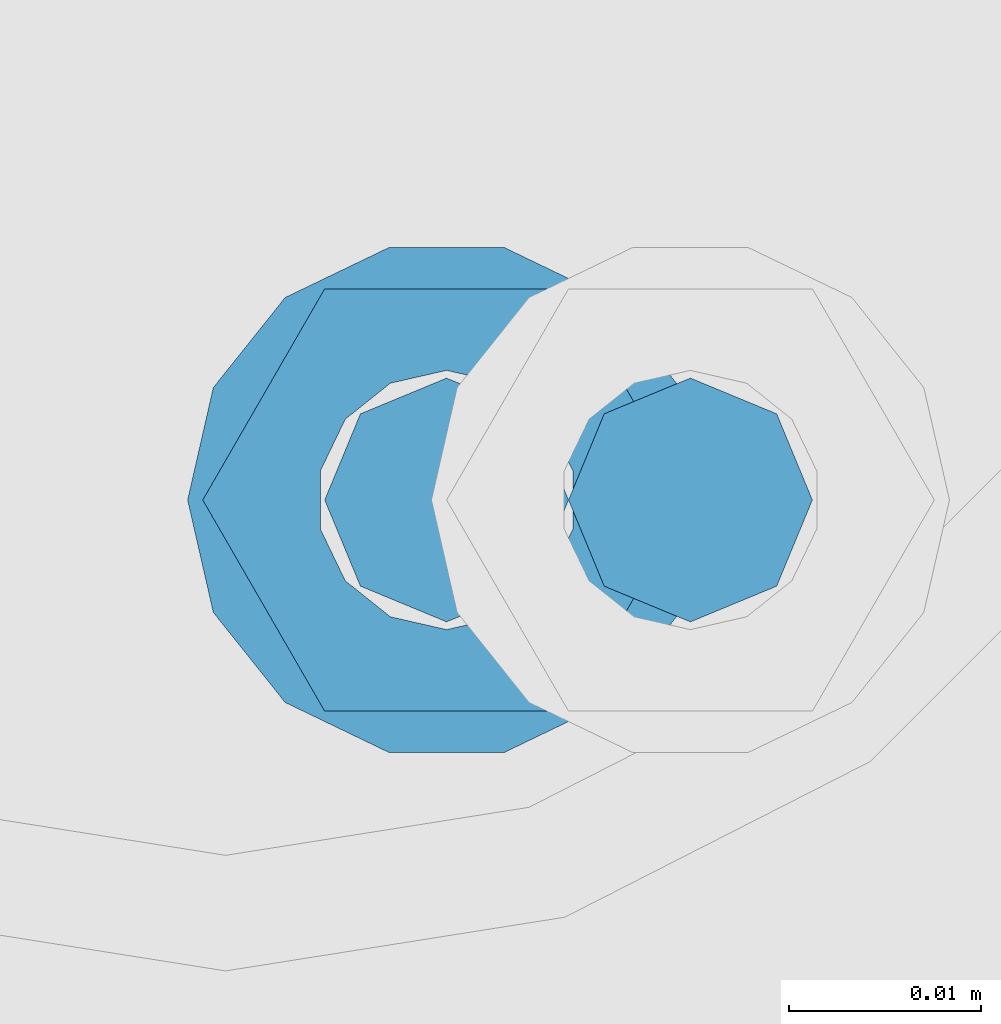
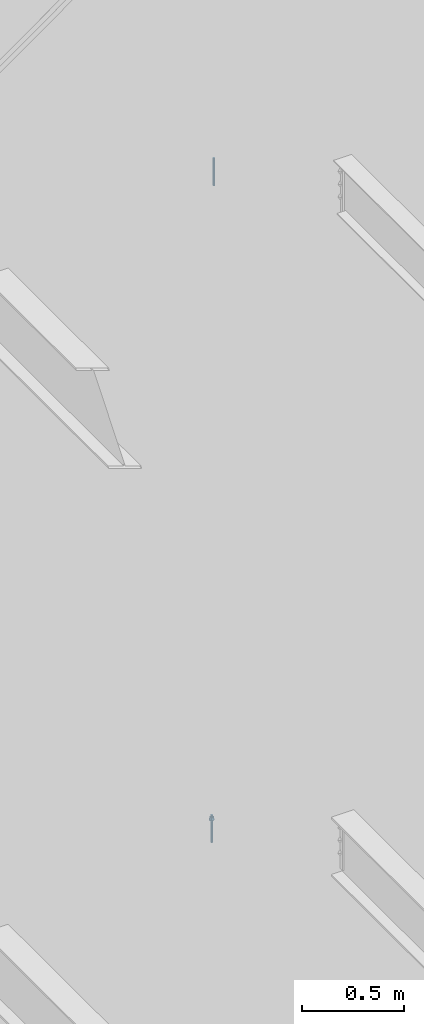
# One storey, part 562 of 1179: 2 columns, 2 elements without a shape of their own.
"""IFC2X3 building model written with IfcOpenShell, lengths in millimetres."""

from ifc_helpers import new_model, si_unit, frame, origin_with_axes, place, context, subcontext, project, spatial, faceted_brep, material, type_object, element, aggregate, save


model = new_model("IFC2X3")

# Units and contexts
model_context = context("Model", 3, precision=1e-05, world=origin_with_axes())
body_context = subcontext(model_context, "Body", "Model", "MODEL_VIEW")
ifc_project = project(units=[si_unit("LENGTHUNIT", "METRE", prefix="MILLI"), si_unit("AREAUNIT", "SQUARE_METRE"), si_unit("VOLUMEUNIT", "CUBIC_METRE"), si_unit("MASSUNIT", "GRAM", prefix="KILO"), si_unit("TIMEUNIT", "SECOND"), si_unit("PLANEANGLEUNIT", "RADIAN"), si_unit("SOLIDANGLEUNIT", "STERADIAN"), si_unit("THERMODYNAMICTEMPERATUREUNIT", "DEGREE_CELSIUS"), si_unit("LUMINOUSINTENSITYUNIT", "LUMEN")], contexts=[model_context])

# Site, building, storey
site_placement = place(None, origin_with_axes())
site = spatial("IfcSite", under=ifc_project, at=site_placement, CompositionType="ELEMENT")
building_placement = place(site_placement, origin_with_axes())
building = spatial("IfcBuilding", under=site, at=building_placement, Name="Undefined", CompositionType="ELEMENT")
storey_placement = place(building_placement, origin_with_axes())
storey = spatial("IfcBuildingStorey", under=building, at=storey_placement, Name="Undefined", CompositionType="ELEMENT", Elevation=0.0)

# Assembly, column
assembly_1_placement = place(storey_placement, origin_with_axes())
assembly_1 = element("IfcElementAssembly", 1, at=assembly_1_placement, inside=storey, Name="BEAM", AssemblyPlace="NOTDEFINED", PredefinedType="RIGID_FRAME")
ifc_material = material(Name="STEEL/A307")
column_type = type_object("IfcColumnType", PredefinedType="NOTDEFINED")
column_1_placement = place(assembly_1_placement, frame((19707.621875, 37985.7, 8013.7), z_axis=(0.0, 1.0, 0.0), x_axis=(0.0, 0.0, 1.0)))
column_1 = element("IfcColumn", 2, at=column_1_placement, type_object=column_type, material=ifc_material, Name="THREADED ROD", context=body_context, shape_type="Brep", body=[
    faceted_brep([(0.0, -6.34999999999854, 0.0), (0.0, -4.49012806053361, -4.49012806053452), (163.512500000001, -4.49012806053361, -4.49012806053452), (163.512500000001, -6.34999999999854, 0.0), (0.0, 0.0, -6.34999999999991), (163.512500000001, 0.0, -6.35000000000036), (0.0, 4.49012806053361, -4.49012806053452), (163.512500000001, 4.49012806053361, -4.49012806053452), (0.0, 6.34999999999854, 0.0), (163.512500000001, 6.34999999999854, 0.0), (0.0, 4.49012806053361, 4.49012806053452), (163.512500000001, 4.49012806053361, 4.49012806053452), (0.0, 0.0, 6.34999999999991), (163.512500000001, 0.0, 6.35000000000036), (0.0, -4.49012806053361, 4.49012806053452), (163.512500000001, -4.49012806053361, 4.49012806053452)], [[[0, 1, 2, 3]], [[1, 4, 5, 2]], [[4, 6, 7, 5]], [[6, 8, 9, 7]], [[8, 10, 11, 9]], [[10, 12, 13, 11]], [[12, 14, 15, 13]], [[14, 0, 3, 15]], [[5, 7, 9, 11, 13, 15, 3, 2]], [[14, 12, 10, 8, 6, 4, 1, 0]]]),
])
aggregate(assembly_1, [column_1])

assembly_2_placement = place(storey_placement, origin_with_axes())
assembly_2 = element("IfcElementAssembly", 3, at=assembly_2_placement, inside=storey, Name="BEAM", AssemblyPlace="NOTDEFINED", PredefinedType="RIGID_FRAME")
column_2_placement = place(assembly_2_placement, frame((19694.921875, 37985.7, 4102.1), z_axis=(0.0, 1.0, 0.0), x_axis=(0.0, 0.0, 1.0)))
column_2 = element("IfcColumn", 4, at=column_2_placement, type_object=column_type, material=ifc_material, Name="THREADED ROD", context=body_context, shape_type="Brep", body=[
    faceted_brep([(0.0, -4.49012806053361, 4.49012806053452), (0.0, -6.34999999999854, 0.0), (163.512500000001, -6.34999999999854, 0.0), (163.512500000001, -4.49012806053361, 4.49012806053452), (0.0, 0.0, 6.34999999999991), (0.0, 4.49012806053361, 4.49012806053452), (0.0, 6.34999999999854, 0.0), (0.0, 4.49012806053361, -4.49012806053452), (0.0, 0.0, -6.34999999999991), (0.0, -4.49012806053361, -4.49012806053452), (163.512500000001, 0.0, 6.35000000000036), (163.512500000001, 4.49012806053361, 4.49012806053452), (163.512500000001, 6.34999999999854, 0.0), (163.512500000001, 4.49012806053361, -4.49012806053452), (163.512500000001, 0.0, -6.35000000000036), (163.512500000001, -4.49012806053361, -4.49012806053452), (133.349999999999, -12.1540698217887, -5.85309154138668), (133.349999999999, -8.41087728436833, -10.5469065195502), (138.112499999999, -8.41087728436833, -10.5469065195502), (138.112499999999, -12.1540698217887, -5.85309154138668), (133.349999999999, -3.00180734814057, -13.1517773121886), (138.112499999999, -3.00180734814057, -13.1517773121886), (133.349999999999, 3.00180734814057, -13.1517773121886), (138.112499999999, 3.00180734814057, -13.1517773121886), (133.349999999999, 8.41087728436833, -10.5469065195502), (138.112499999999, 8.41087728436833, -10.5469065195502), (133.349999999999, 12.1540698217887, -5.85309154138668), (138.112499999999, 12.1540698217887, -5.85309154138668), (133.349999999999, 13.4899997711182, 0.0), (138.112499999999, 13.4899997711182, 0.0), (133.349999999999, 12.1540698217887, 5.85309154138668), (138.112499999999, 12.1540698217887, 5.85309154138668), (133.349999999999, 8.41087728436833, 10.5469065195502), (138.112499999999, 8.41087728436833, 10.5469065195502), (133.349999999999, 3.00180734814057, 13.1517773121886), (138.112499999999, 3.00180734814057, 13.1517773121886), (133.349999999999, -3.00180734814057, 13.1517773121886), (138.112499999999, -3.00180734814057, 13.1517773121886), (133.349999999999, -8.41087728436833, 10.5469065195502), (138.112499999999, -8.41087728436833, 10.5469065195502), (133.349999999999, -12.1540698217887, 5.85309154138668), (138.112499999999, -12.1540698217887, 5.85309154138668), (133.349999999999, -13.4899997711182, 0.0), (138.112499999999, -13.4899997711182, 0.0), (138.112499999999, -12.6999998092651, 0.0), (138.112499999999, -6.34999990463257, 11.0), (138.112499999999, 6.34999990463257, 11.0), (138.112499999999, 12.6999998092651, 0.0), (138.112499999999, 6.34999990463257, -11.0), (138.112499999999, -6.34999990463257, -11.0), (133.349999999999, -2.92871523904432, 6.0815398583436), (133.349999999999, -5.27736250665839, 4.20855616254994), (133.349999999999, -6.58076340722801, 1.50201630420634), (133.349999999999, -6.58076340722801, -1.50201630420634), (133.349999999999, -5.27736250665839, -4.20855616254994), (133.349999999999, -2.92871523904432, -6.0815398583436), (133.349999999999, 0.0, -6.75), (133.349999999999, 2.92871523904432, -6.0815398583436), (133.349999999999, 5.27736250665839, -4.20855616254994), (133.349999999999, 6.58076340722801, -1.50201630420634), (133.349999999999, 6.58076340722801, 1.50201630420634), (133.349999999999, 5.27736250665839, 4.20855616254994), (133.349999999999, 2.92871523904432, 6.0815398583436), (133.349999999999, 0.0, 6.75), (150.812499999999, -2.92871523904432, 6.0815398583436), (150.812499999999, 0.0, 6.75), (150.812499999999, -5.27736250665839, 4.20855616254994), (150.812499999999, -6.58076340722801, 1.50201630420634), (150.812499999999, -5.27736250665839, -4.20855616254994), (150.812499999999, -6.58076340722801, -1.50201630420634), (150.812499999999, -2.92871523904432, -6.0815398583436), (150.812499999999, 0.0, -6.75), (150.812499999999, 2.92871523904432, -6.0815398583436), (150.812499999999, 5.27736250665839, -4.20855616254994), (150.812499999999, 6.58076340722801, -1.50201630420634), (150.812499999999, 5.27736250665839, 4.20855616254994), (150.812499999999, 6.58076340722801, 1.50201630420634), (150.812499999999, 2.92871523904432, 6.0815398583436), (150.812499999999, -12.6999998092651, 0.0), (150.812499999999, -6.34999990463257, 11.0), (150.812499999999, 6.34999990463257, -11.0), (150.812499999999, -6.34999990463257, -11.0), (150.812499999999, 12.6999998092651, 0.0), (150.812499999999, 6.34999990463257, 11.0)], [[[0, 1, 2, 3]], [[0, 4, 5, 6, 7, 8, 9, 1]], [[5, 4, 10, 11]], [[6, 5, 11, 12]], [[7, 6, 12, 13]], [[8, 7, 13, 14]], [[9, 8, 14, 15]], [[1, 9, 15, 2]], [[14, 13, 12, 11, 10, 3, 2, 15]], [[4, 0, 3, 10]], [[16, 17, 18, 19]], [[17, 20, 21, 18]], [[20, 22, 23, 21]], [[22, 24, 25, 23]], [[24, 26, 27, 25]], [[26, 28, 29, 27]], [[28, 30, 31, 29]], [[30, 32, 33, 31]], [[32, 34, 35, 33]], [[34, 36, 37, 35]], [[36, 38, 39, 37]], [[38, 40, 41, 39]], [[40, 42, 43, 41]], [[18, 21, 23, 25, 27, 29, 31, 33, 35, 37, 39, 41, 43, 19], [44, 45, 46, 47, 48, 49]], [[42, 16, 19, 43]], [[40, 38, 36, 34, 32, 30, 28, 26, 24, 22, 20, 17, 16, 42], [50, 51, 52, 53, 54, 55, 56, 57, 58, 59, 60, 61, 62, 63]], [[64, 50, 63, 65]], [[66, 51, 50, 64]], [[67, 52, 51, 66]], [[68, 54, 53, 69]], [[70, 55, 54, 68]], [[71, 56, 55, 70]], [[72, 57, 56, 71]], [[73, 58, 57, 72]], [[74, 59, 58, 73]], [[75, 61, 60, 76]], [[77, 62, 61, 75]], [[77, 65, 63, 62]], [[78, 79, 45, 44]], [[80, 81, 49, 48]], [[82, 80, 48, 47]], [[83, 82, 47, 46]], [[79, 83, 46, 45]], [[81, 78, 44, 49]], [[53, 52, 67, 69]], [[60, 59, 74, 76]], [[80, 82, 83, 79, 78, 81], [75, 76, 74, 73, 72, 71, 70, 68, 69, 67, 66, 64, 65, 77]]]),
])
aggregate(assembly_2, [column_2])

save(model, "model.ifc")
